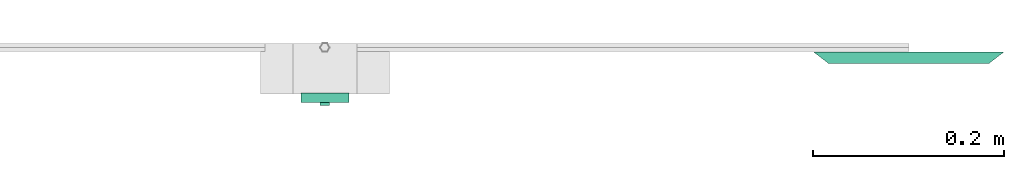
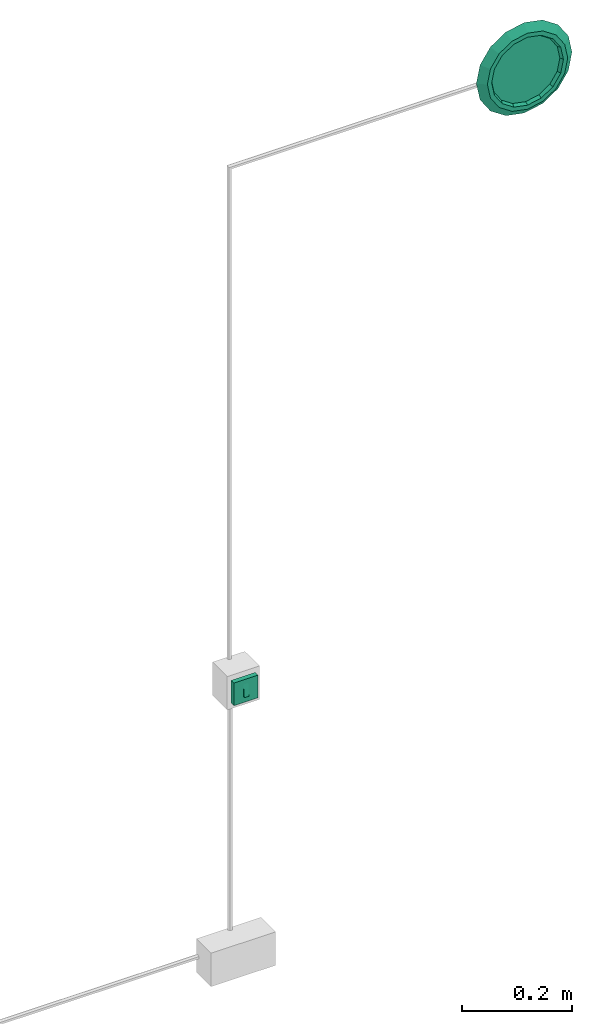
# One storey, part 4 of 4: 1 light fixture, 1 switching device.
"""IFC4X3_ADD2 building model written with IfcOpenShell, lengths in metres."""

from ifc_helpers import new_model, entity, si_unit, converted_unit, frame, origin_with_axes, origin_2d_with_axis, place, context, subcontext, project, spatial, polygons, source, transform, mapped, type_object, type_shapes, element, save


model = new_model("IFC4X3_ADD2")

# Units and contexts
model_context = context("Model", 3, precision=1e-05, world=origin_with_axes())
plan_context = context("Plan", 2, precision=1e-05, world=origin_2d_with_axis())
body_context = subcontext(model_context, "Body", "Model", "MODEL_VIEW")
ifc_project = project(units=[si_unit("VOLUMEUNIT", "CUBIC_METRE"), si_unit("LENGTHUNIT", "METRE"), converted_unit("PLANEANGLEUNIT", "degree", entity("IfcReal", 0.0174532925199433), si_unit("PLANEANGLEUNIT", "RADIAN"), dimensions=[0, 0, 0, 0, 0, 0, 0]), si_unit("AREAUNIT", "SQUARE_METRE")], contexts=[model_context, plan_context])

# Site, building, storey
site_placement = place(None, origin_with_axes())
site = spatial("IfcSite", under=ifc_project, at=site_placement)
building_placement = place(site_placement, origin_with_axes())
building = spatial("IfcBuilding", under=site, at=building_placement, Name="Building")
storey_placement = place(building_placement, origin_with_axes())
storey = spatial("IfcBuildingStorey", under=building, at=storey_placement, Name="Storey")

# Light fixture
light_fixture_type = type_object("IfcLightFixtureType", Name="light20W", PredefinedType="POINTSOURCE")
shared_shape_1 = source(origin_with_axes(), body_context, "Body", "Tessellation", [
    polygons([(0.0, -4.37113900630948e-09, 0.100000001490116), (-0.0382683463394642, -4.03840560991853e-09, 0.0923879519104958), (-0.0707106813788414, -3.09086201077946e-09, 0.0707106813788414), (-0.0923879519104958, -1.67276259510629e-09, 0.0382683463394642), (-0.100000001490116, 0.0, 0.0), (-0.0923879519104958, 1.67276259510629e-09, -0.0382683463394642), (-0.0707106813788414, 3.09086201077946e-09, -0.0707106813788414), (-0.0382683463394642, 4.03840560991853e-09, -0.0923879519104958), (0.0, 4.37113900630948e-09, -0.100000001490116), (0.0382683463394642, 4.03840560991853e-09, -0.0923879519104958), (0.0707106813788414, 3.09086201077946e-09, -0.0707106813788414), (0.0923879519104958, 1.67276259510629e-09, -0.0382683463394642), (0.100000001490116, 0.0, 0.0), (0.0923879519104958, -1.67276259510629e-09, 0.0382683463394642), (0.0707106813788414, -3.09086201077946e-09, 0.0707106813788414), (0.0382683463394642, -4.03840560991853e-09, 0.0923879519104958), (-0.0273770838975906, -0.00532466033473611, 0.0660941153764725), (0.0, -0.0053246608003974, 0.0715397596359253), (-0.0505862459540367, -0.00532465986907482, 0.0505862459540367), (-0.0660941153764725, -0.00532465893775225, 0.0273770838975906), (-0.0715397596359253, -0.00532465754076838, -1.38777878078145e-17), (-0.0660941153764725, -0.00532465614378452, -0.0273770838975906), (-0.0505862459540367, -0.00532465521246195, -0.0505862459540367), (-0.0273770838975906, -0.00532465474680066, -0.0660941153764725), (0.0, -0.00532465428113937, -0.0715397596359253), (0.0273770838975906, -0.00532465474680066, -0.0660941153764725), (0.0505862459540367, -0.00532465521246195, -0.0505862459540367), (0.0660941153764725, -0.00532465614378452, -0.0273770838975906), (0.0715397596359253, -0.00532465754076838, -1.38777878078145e-17), (0.0660941153764725, -0.00532465893775225, 0.0273770838975906), (0.0505862459540367, -0.00532465986907482, 0.0505862459540367), (0.0273770838975906, -0.00532466033473611, 0.0660941153764725), (-0.0321705304086208, -0.0122796511277556, 0.0776665210723877), (0.0, -0.0122796511277556, 0.0840656384825706), (-0.0594433844089508, -0.0122796501964331, 0.0594433844089508), (-0.0776665210723877, -0.0122796492651105, 0.0321705304086208), (-0.0840656384825706, -0.0122796474024653, 0.0), (-0.0776665210723877, -0.0122796455398202, -0.0321705304086208), (-0.0594433844089508, -0.0122796446084976, -0.0594433844089508), (-0.0321705304086208, -0.012279643677175, -0.0776665210723877), (0.0, -0.012279643677175, -0.0840656384825706), (0.0321705304086208, -0.012279643677175, -0.0776665210723877), (0.0594433844089508, -0.0122796446084976, -0.0594433844089508), (0.0776665210723877, -0.0122796455398202, -0.0321705304086208), (0.0840656384825706, -0.0122796474024653, 0.0), (0.0776665210723877, -0.0122796492651105, 0.0321705304086208), (0.0594433844089508, -0.0122796501964331, 0.0594433844089508), (0.0321705304086208, -0.0122796511277556, 0.0776665210723877), (-0.028736149892211, -0.0122796501964331, 0.0693751946091652), (0.0, -0.0122796511277556, 0.0750911682844162), (-0.0530974753201008, -0.0122796492651105, 0.0530974753201008), (-0.0693751946091652, -0.0122796483337879, 0.028736149892211), (-0.0750911682844162, -0.0122796474024653, 0.0), (-0.0693751946091652, -0.0122796464711428, -0.028736149892211), (-0.0530974753201008, -0.0122796455398202, -0.0530974753201008), (-0.028736149892211, -0.0122796446084976, -0.0693751946091652), (0.0, -0.012279643677175, -0.0750911682844162), (0.028736149892211, -0.0122796446084976, -0.0693751946091652), (0.0530974753201008, -0.0122796455398202, -0.0530974753201008), (0.0693751946091652, -0.0122796464711428, -0.028736149892211), (0.0750911682844162, -0.0122796474024653, 0.0), (0.0693751946091652, -0.0122796483337879, 0.028736149892211), (0.0530974753201008, -0.0122796492651105, 0.0530974753201008), (0.028736149892211, -0.0122796501964331, 0.0693751946091652)], [[[17, 19, 20, 21, 22, 23, 24, 25, 26, 27, 28, 29, 30, 31, 32, 18]], [[33, 34, 1, 2]], [[35, 33, 2, 3]], [[36, 35, 3, 4]], [[37, 36, 4, 5]], [[38, 37, 5, 6]], [[39, 38, 6, 7]], [[40, 39, 7, 8]], [[41, 40, 8, 9]], [[42, 41, 9, 10]], [[43, 42, 10, 11]], [[44, 43, 11, 12]], [[45, 44, 12, 13]], [[46, 45, 13, 14]], [[47, 46, 14, 15]], [[48, 47, 15, 16]], [[34, 48, 16, 1]], [[49, 50, 34, 33]], [[51, 49, 33, 35]], [[52, 51, 35, 36]], [[53, 52, 36, 37]], [[54, 53, 37, 38]], [[55, 54, 38, 39]], [[56, 55, 39, 40]], [[57, 56, 40, 41]], [[58, 57, 41, 42]], [[59, 58, 42, 43]], [[60, 59, 43, 44]], [[61, 60, 44, 45]], [[62, 61, 45, 46]], [[63, 62, 46, 47]], [[64, 63, 47, 48]], [[50, 64, 48, 34]], [[17, 18, 50, 49]], [[19, 17, 49, 51]], [[20, 19, 51, 52]], [[21, 20, 52, 53]], [[22, 21, 53, 54]], [[23, 22, 54, 55]], [[24, 23, 55, 56]], [[25, 24, 56, 57]], [[26, 25, 57, 58]], [[27, 26, 58, 59]], [[28, 27, 59, 60]], [[29, 28, 60, 61]], [[30, 29, 61, 62]], [[31, 30, 62, 63]], [[32, 31, 63, 64]], [[18, 32, 64, 50]]]),
])
type_shapes(light_fixture_type, [shared_shape_1])
light_fixture_placement = place(storey_placement, frame((1.66400480270386, 0.0851021185517311, 2.16725993156433), z_axis=(0.0, 0.0, 1.0), x_axis=(1.0, 0.0, 0.0)))
element("IfcLightFixture", 1, at=light_fixture_placement, inside=storey, type_object=light_fixture_type, Name="light20W", context=body_context, shape_type="MappedRepresentation", body=[
    mapped(shared_shape_1, transform((0.0, 0.0, 0.0), x_axis=(1.0, 0.0, 0.0), y_axis=(0.0, 1.0, 0.0), z_axis=(0.0, 0.0, 1.0), scale=1.0)),
])

# Switching device
switching_device_type = type_object("IfcSwitchingDeviceType", Name="switch1P1G", PredefinedType="CONTACTOR")
shared_shape_2 = source(origin_with_axes(), body_context, "Body", "Tessellation", [
    polygons([(-0.025000000372529, 1.09278475157737e-09, -0.025000000372529), (0.025000000372529, 1.09278475157737e-09, -0.025000000372529), (-0.025000000372529, -1.09278475157737e-09, 0.025000000372529), (0.025000000372529, -1.09278475157737e-09, 0.025000000372529), (-0.00500000175088644, -0.0100000007078052, 0.0146210212260485), (0.00500000640749931, -0.0100000007078052, 0.0146210212260485), (-0.025000000372529, -0.0100000007078052, 0.025000000372529), (-0.025000000372529, -0.00999999884516001, -0.025000000372529), (0.025000000372529, -0.00999999884516001, -0.025000000372529), (0.025000000372529, -0.0100000007078052, 0.025000000372529), (-0.00500000175088644, -0.00999999884516001, -0.0125717325136065), (0.00500000640749931, -0.00999999884516001, -0.012571613304317), (0.00500000640749931, -0.0131387999281287, -0.0125716077163815), (-0.00500000175088644, -0.0131387999281287, -0.0125717082992196)], [[[1, 3, 4, 2]], [[1, 2, 9, 8]], [[2, 4, 10, 9]], [[3, 1, 8, 7]], [[4, 3, 7, 10]], [[11, 14, 5]], [[11, 12, 13, 14]], [[14, 13, 6, 5]], [[6, 10, 7, 5]], [[12, 9, 10, 6]], [[11, 8, 9, 12]], [[13, 12, 6]], [[8, 11, 5, 7]]]),
])
type_shapes(switching_device_type, [shared_shape_2])
switching_device_placement = place(storey_placement, frame((1.05111503601074, 0.0420266427099705, 1.03699994087219), z_axis=(0.0, 0.0, 1.0), x_axis=(1.0, 0.0, 0.0)))
element("IfcSwitchingDevice", 2, at=switching_device_placement, inside=storey, type_object=switching_device_type, Name="switch1P1G", context=body_context, shape_type="MappedRepresentation", body=[
    mapped(shared_shape_2, transform((0.0, 0.0, 0.0), x_axis=(1.0, 0.0, 0.0), y_axis=(0.0, 1.0, 0.0), z_axis=(0.0, 0.0, 1.0), scale=1.0)),
])

save(model, "model.ifc")
